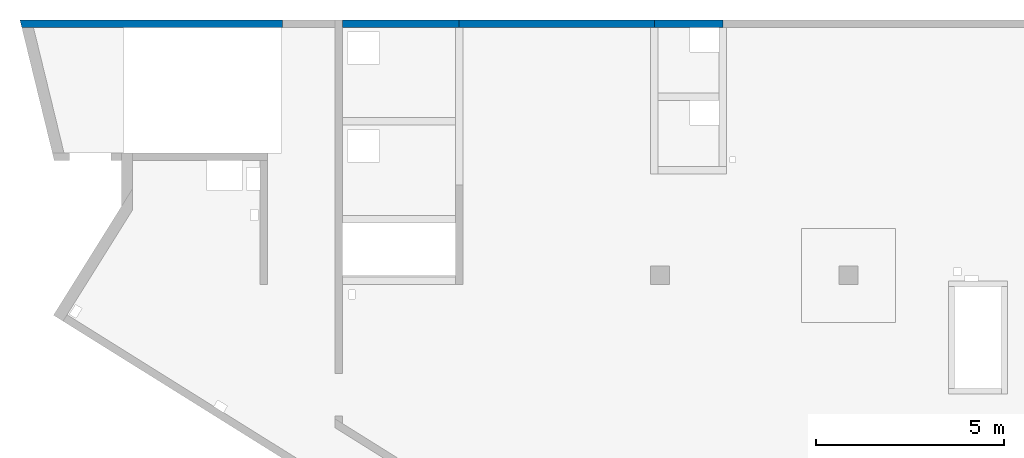
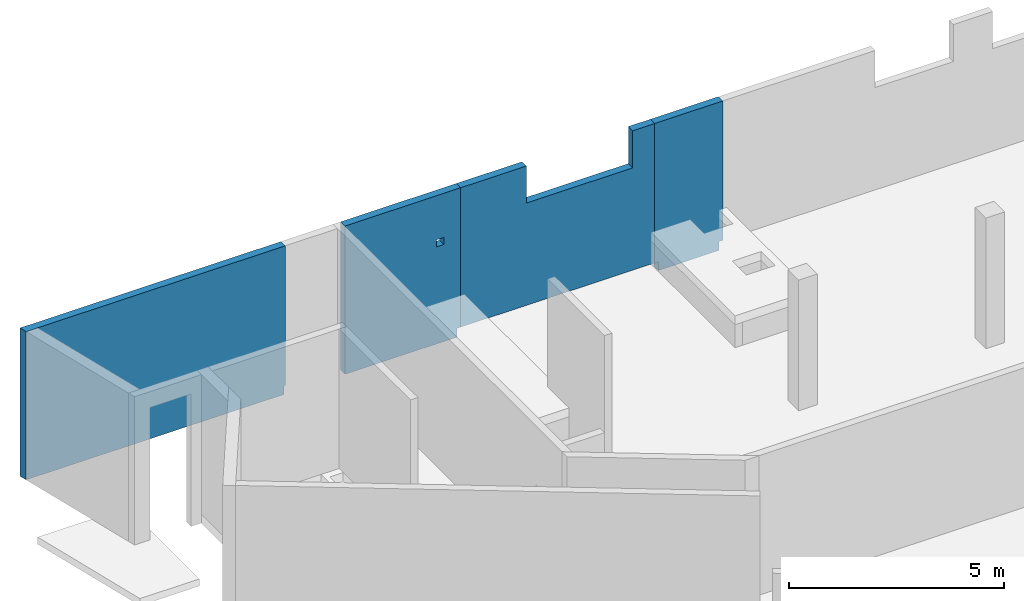
# One storey, part 4 of 6: 4 walls, 2 openings.
"""IFC4 building model written with IfcOpenShell, lengths in millimetres."""

from ifc_helpers import new_model, entity, si_unit, converted_unit, derived_unit, direction, frame, origin, place, context, subcontext, project, spatial, indexed_curve, outline, extrude, polygons, material, type_object, element, save


model = new_model("IFC4")

# Units and contexts
model_context = context("Model", 3, precision=0.01, world=origin(), true_north=direction((6.12303176911189e-17, 1.0)))
plan_context = context("Plan", 3, precision=0.01, world=origin(), true_north=direction((6.12303176911189e-17, 1.0)))
body_context = subcontext(model_context, "Body", "Model", "MODEL_VIEW")
ifc_project = project(units=[si_unit("LENGTHUNIT", "METRE", prefix="MILLI"), si_unit("AREAUNIT", "SQUARE_METRE"), si_unit("VOLUMEUNIT", "CUBIC_METRE"), converted_unit("PLANEANGLEUNIT", "DEGREE", entity("IfcRatioMeasure", 0.0174532925199433), si_unit("PLANEANGLEUNIT", "RADIAN"), dimensions=[0, 0, 0, 0, 0, 0, 0]), si_unit("MASSUNIT", "GRAM", prefix="KILO"), derived_unit("MASSDENSITYUNIT", [(si_unit("MASSUNIT", "GRAM", prefix="KILO"), 1), (si_unit("LENGTHUNIT", "METRE"), -3)]), derived_unit("MOMENTOFINERTIAUNIT", [(si_unit("LENGTHUNIT", "METRE"), 4)]), si_unit("TIMEUNIT", "SECOND"), si_unit("FREQUENCYUNIT", "HERTZ"), si_unit("THERMODYNAMICTEMPERATUREUNIT", "DEGREE_CELSIUS"), derived_unit("THERMALTRANSMITTANCEUNIT", [(si_unit("MASSUNIT", "GRAM", prefix="KILO"), 1), (si_unit("THERMODYNAMICTEMPERATUREUNIT", "KELVIN"), -1), (si_unit("TIMEUNIT", "SECOND"), -3)]), derived_unit("VOLUMETRICFLOWRATEUNIT", [(si_unit("LENGTHUNIT", "METRE"), 3), (si_unit("TIMEUNIT", "SECOND"), -1)]), derived_unit("MASSFLOWRATEUNIT", [(si_unit("MASSUNIT", "GRAM", prefix="KILO"), 1), (si_unit("TIMEUNIT", "SECOND"), -1)]), derived_unit("ROTATIONALFREQUENCYUNIT", [(si_unit("TIMEUNIT", "SECOND"), -1)]), si_unit("ELECTRICCURRENTUNIT", "AMPERE"), si_unit("ELECTRICVOLTAGEUNIT", "VOLT"), si_unit("POWERUNIT", "WATT"), si_unit("FORCEUNIT", "NEWTON", prefix="KILO"), si_unit("ILLUMINANCEUNIT", "LUX"), si_unit("LUMINOUSFLUXUNIT", "LUMEN"), si_unit("LUMINOUSINTENSITYUNIT", "CANDELA"), derived_unit("USERDEFINED", [(si_unit("MASSUNIT", "GRAM", prefix="KILO"), -1), (si_unit("LENGTHUNIT", "METRE"), -2), (si_unit("TIMEUNIT", "SECOND"), 3), (si_unit("LUMINOUSFLUXUNIT", "LUMEN"), 1)]), derived_unit("LINEARVELOCITYUNIT", [(si_unit("LENGTHUNIT", "METRE"), 1), (si_unit("TIMEUNIT", "SECOND"), -1)]), si_unit("PRESSUREUNIT", "PASCAL"), derived_unit("USERDEFINED", [(si_unit("LENGTHUNIT", "METRE"), -2), (si_unit("MASSUNIT", "GRAM", prefix="KILO"), 1), (si_unit("TIMEUNIT", "SECOND"), -2)]), derived_unit("LINEARFORCEUNIT", [(si_unit("MASSUNIT", "GRAM", prefix="KILO"), 1), (si_unit("LENGTHUNIT", "METRE"), 1), (si_unit("TIMEUNIT", "SECOND"), -2), (si_unit("LENGTHUNIT", "METRE"), -1)]), derived_unit("PLANARFORCEUNIT", [(si_unit("MASSUNIT", "GRAM", prefix="KILO"), 1), (si_unit("LENGTHUNIT", "METRE"), 1), (si_unit("TIMEUNIT", "SECOND"), -2), (si_unit("LENGTHUNIT", "METRE"), -2)])], contexts=[model_context, plan_context])

# Site, building, storey
site_placement = place(None, origin())
site = spatial("IfcSite", under=ifc_project, at=site_placement, CompositionType="ELEMENT")
building_placement = place(site_placement, origin())
building = spatial("IfcBuilding", under=site, at=building_placement, CompositionType="ELEMENT")
storey_placement = place(building_placement, frame((0.0, 0.0, 28200.0)))
storey = spatial("IfcBuildingStorey", under=building, at=storey_placement, Name="08", CompositionType="ELEMENT", Elevation=28200.0)

# Wall
ifc_material = material()
wall_type = type_object("IfcWallType", Name=":ADSK_ 25_200", PredefinedType="STANDARD")
wall_1_placement = place(storey_placement, frame((-892.38, 20400.0, -400.0)))
element("IfcWall", 1, at=wall_1_placement, inside=storey, type_object=wall_type, material=ifc_material, Name=":ADSK_ 25_200", ObjectType=":ADSK_ 25_200", PredefinedType="NOTDEFINED", context=body_context, shape_type="Tessellation", body=[
    polygons([(6992.37911798968, -99.9999999999989, 4200.0), (357.536393121909, -99.9999999999989, 4200.0), (48.7521159583308, -100.000000000003, 4200.0), (48.7521159583318, -100.000000000003, 0.0), (357.536393121908, -99.9999999999989, 0.0), (6962.37911798968, -99.9999999999989, 0.0), (6962.37911798968, -99.9999999999989, 249.999999999999), (6992.37911798968, -99.9999999999989, 249.999999999999), (8.98797485695457e-13, 99.9999999999989, 4200.0), (0.379117989658529, 99.9999999999989, 4200.0), (6992.37911798968, 100.000000000003, 4200.0), (6992.37911798968, 100.000000000003, 249.999999999999), (6962.37911798968, 100.000000000008, 249.999999999999), (6962.37911798968, 100.000000000003, 0.0), (308.784277163562, 100.000000000003, 0.0), (-4.87112524406362e-14, 99.9999999999989, 0.0)], [[[1, 2, 3, 4, 5, 6, 7, 8]], [[9, 10, 11, 12, 13, 14, 15, 16]], [[4, 16, 15, 14, 6, 5]], [[11, 1, 8, 12]], [[3, 2, 1, 11, 10, 9]], [[4, 3, 9, 16]], [[7, 13, 12, 8]], [[13, 7, 6, 14]]], closed=True),
])

# Wall, opening
wall_2_placement = place(storey_placement, frame((7700.0, 20400.0, -400.0)))
wall_2 = element("IfcWall", 2, at=wall_2_placement, inside=storey, type_object=wall_type, material=ifc_material, Name=":ADSK_ 25_200", ObjectType=":ADSK_ 25_200", PredefinedType="NOTDEFINED", context=body_context, shape_type="Tessellation", body=[
    polygons([(3099.99999999999, -99.9999999999989, 4200.0), (-1.44381896161168e-13, -99.9999999999989, 4200.0), (-1.44381896161168e-13, -99.9999999999989, 1150.0), (-1.44381896161168e-13, -99.9999999999989, 899.999999999999), (-1.44381896161168e-13, -99.9999999999989, 249.999999999999), (-1.44381896161168e-13, -99.9999999999989, 0.0), (3000.0, -99.9999999999989, 0.0), (3000.0, -99.9999999999989, 249.999999999999), (3099.99999999999, -99.9999999999989, 249.999999999999), (2449.99999999998, -99.9999999999989, 2950.0), (2649.99999999998, -99.9999999999989, 2950.0), (2649.99999999998, -99.9999999999989, 2750.00000000001), (2449.99999999998, -99.9999999999989, 2750.00000000001), (-7.21911031786967e-13, 99.9999999999989, 4200.0), (3099.99999999999, 99.9999999999989, 4200.0), (3099.99999999999, 99.9999999999989, 249.999999999999), (3000.0, 99.9999999999946, 249.999999999999), (3000.0, 99.9999999999989, 0.0), (-7.21911031786967e-13, 99.9999999999989, 0.0), (-7.21911031786967e-13, 99.9999999999989, 249.999999999999), (2649.99999999998, 100.000000000319, 2950.0), (2449.99999999998, 100.000000000319, 2950.0), (2449.99999999998, 100.000000000319, 2750.00000000001), (2649.99999999998, 100.000000000319, 2750.00000000001)], [[[1, 2, 3, 4, 5, 6, 7, 8, 9], [10, 11, 12, 13]], [[14, 15, 16, 17, 18, 19, 20], [21, 22, 23, 24]], [[6, 19, 18, 7]], [[2, 1, 15, 14]], [[2, 14, 20, 19, 6, 5, 4, 3]], [[15, 1, 9, 16]], [[8, 17, 16, 9]], [[17, 8, 7, 18]], [[22, 21, 11, 10]], [[22, 10, 13, 23]], [[23, 13, 12, 24]], [[11, 21, 24, 12]]], closed=True),
])
opening_1_placement = place(wall_2_placement, frame((-7700.0, -20400.0, 400.0)))
element("IfcOpeningElement", 3, at=opening_1_placement, cuts=wall_2, Name=":ADSK_ 25_200", PredefinedType="OPENING", context=body_context, shape_type="SweptSolid", body=[
    extrude(outline(indexed_curve([(-99.9999999999946, -99.9999999999989), (99.9999999999903, -99.9999999999989), (99.9999999999903, 100.000000000001), (-99.9999999999946, 100.000000000001), (-99.9999999999946, -99.9999999999989)], self_intersect=False)), frame((10250.0, 20300.0, 2450.0), z_axis=(0.0, 1.0, 0.0), x_axis=(0.0, 0.0, -1.0)), (0.0, 0.0, 1.0), 200.000000000959),
])

# Wall
wall_3_placement = place(storey_placement, frame((16000.0, 20400.0, -400.0)))
element("IfcWall", 4, at=wall_3_placement, inside=storey, type_object=wall_type, material=ifc_material, Name=":ADSK_ 25_200", ObjectType=":ADSK_ 25_200", PredefinedType="NOTDEFINED", context=body_context, shape_type="Tessellation", body=[
    polygons([(1824.99999999998, -99.9999999999989, 4200.0), (3.33193465125452e-14, -99.9999999999989, 4200.0), (3.33193465125452e-14, -99.9999999999989, 249.999999999999), (99.9999999999925, -99.9999999999989, 249.999999999999), (99.9999999999925, -99.9999999999989, 0.0), (1724.99999999999, -99.9999999999989, 0.0), (1724.99999999999, -99.9999999999989, 249.999999999999), (1824.99999999998, -99.9999999999989, 249.999999999999), (-4.997844709882e-13, 99.9999999999989, 4200.0), (1824.99999999998, 99.9999999999989, 4200.0), (1824.99999999998, 99.9999999999989, 249.999999999999), (1724.99999999999, 100.000000000051, 249.999999999999), (1724.99999999999, 99.9999999999989, 0.0), (99.9999999999919, 99.9999999999989, 0.0), (99.9999999999919, 99.9999999999946, 249.999999999999), (-4.997844709882e-13, 99.9999999999989, 249.999999999999)], [[[1, 2, 3, 4, 5, 6, 7, 8]], [[9, 10, 11, 12, 13, 14, 15, 16]], [[6, 5, 14, 13]], [[2, 1, 10, 9]], [[2, 9, 16, 3]], [[10, 1, 8, 11]], [[15, 4, 3, 16]], [[4, 15, 14, 5]], [[12, 7, 6, 13]], [[7, 12, 11, 8]]], closed=True),
])

# Wall, opening
wall_4_placement = place(storey_placement, frame((10800.0, 20400.0, -150.0)))
wall_4 = element("IfcWall", 5, at=wall_4_placement, inside=storey, type_object=wall_type, material=ifc_material, Name=":ADSK_ 25_200", ObjectType=":ADSK_ 25_200", PredefinedType="NOTDEFINED", context=body_context, shape_type="Tessellation", body=[
    polygons([(-1.60424329067794e-13, -99.9999999999989, 0.0), (100.000000000001, -99.9999999999989, 0.0), (5100.00000000003, -99.9999999999989, 0.0), (5200.00000000003, -99.9999999999989, 0.0), (5200.00000000003, -99.9999999999989, 3950.0), (4610.00000000002, -99.9999999999989, 3950.0), (4610.00000000002, -100.000000000319, 2900.00000000001), (1760.00000000002, -100.000000000319, 2900.00000000001), (1760.00000000002, -99.9999999999989, 3950.0), (-1.60424329067794e-13, -99.9999999999989, 3950.0), (5200.00000000003, 99.9999999999989, 0.0), (-8.02123368652022e-13, 99.9999999999989, 0.0), (-8.02123368652022e-13, 99.9999999999989, 3950.0), (1760.00000000002, 99.9999999999989, 3950.0), (1760.00000000002, 99.9999999999989, 2900.00000000001), (4610.00000000002, 99.9999999999989, 2900.00000000002), (4610.00000000002, 99.9999999999989, 3950.0), (5200.00000000003, 99.9999999999989, 3950.0)], [[[1, 2, 3, 4, 5, 6, 7, 8, 9, 10]], [[11, 12, 13, 14, 15, 16, 17, 18]], [[4, 3, 2, 1, 12, 11]], [[5, 18, 17, 6]], [[10, 13, 12, 1]], [[4, 11, 18, 5]], [[16, 7, 6, 17]], [[7, 16, 15, 8]], [[8, 15, 14, 9]], [[13, 10, 9, 14]]], closed=True),
])
opening_2_placement = place(wall_4_placement, frame((-10800.0, -20400.0, 150.0)))
element("IfcOpeningElement", 6, at=opening_2_placement, cuts=wall_4, Name=":ADSK_ 25_200", PredefinedType="OPENING", context=body_context, shape_type="SweptSolid", body=[
    extrude(outline(indexed_curve([(-1425.0, -524.999999999993), (1425.0, -524.999999999993), (1425.0, 524.999999999993), (-1425.0, 524.999999999993), (-1425.0, -524.999999999993)], self_intersect=False)), frame((13985.0, 20300.0, 3275.0), z_axis=(0.0, 1.0, 0.0), x_axis=(1.0, 0.0, 0.0)), (0.0, 0.0, 1.0), 200.000000000959),
])

save(model, "model.ifc")
